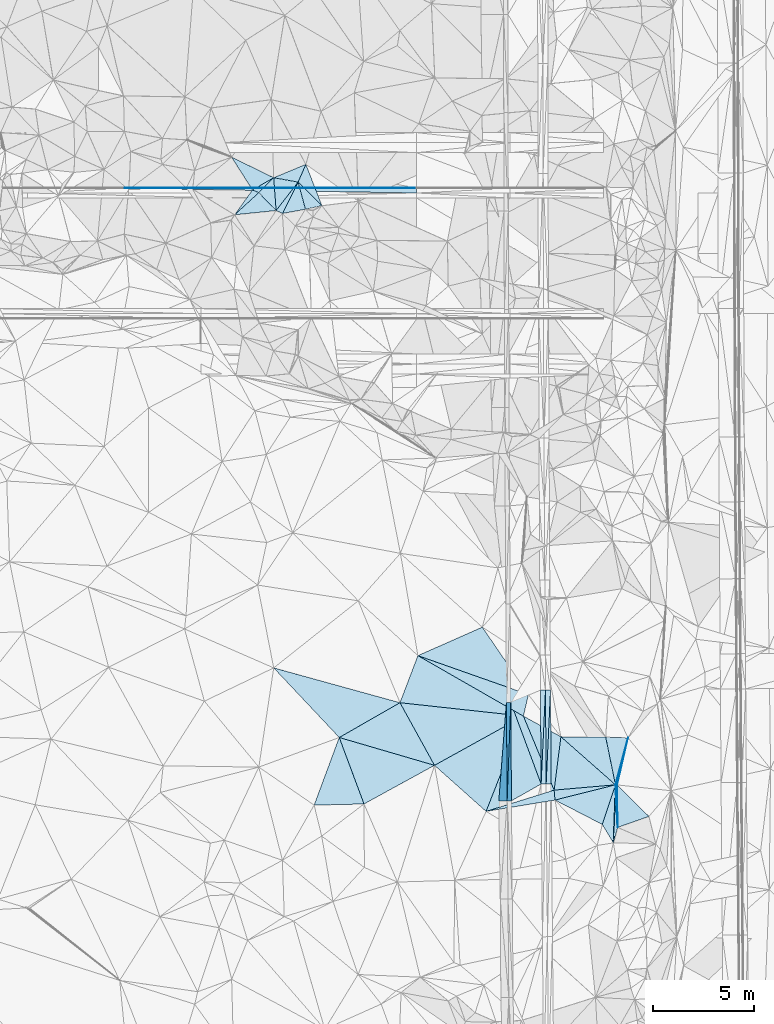
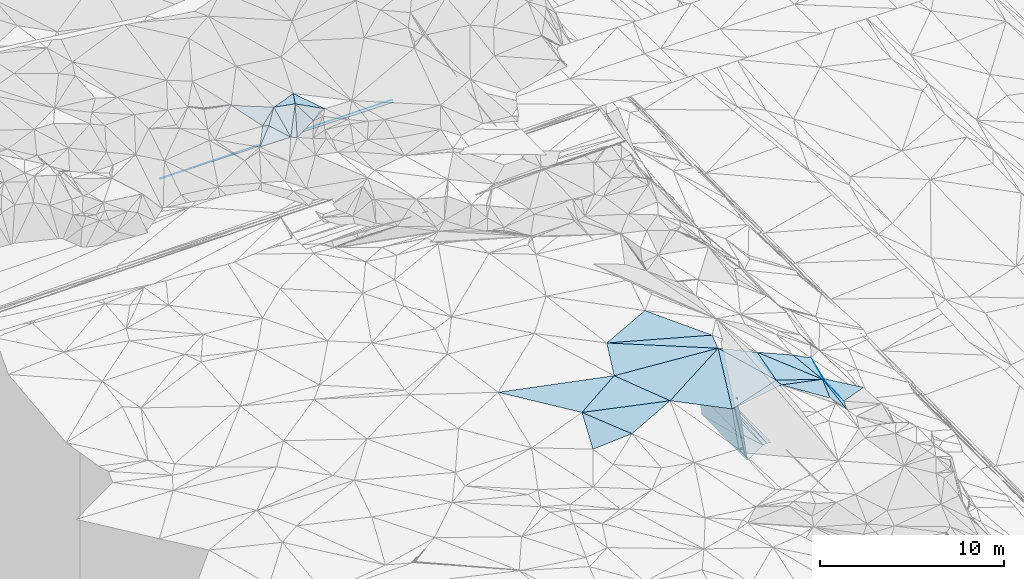
# One storey, part 51 of 275: 45 plates.
"""IFC2X3 building model written with IfcOpenShell, lengths in millimetres."""

from ifc_helpers import new_model, si_unit, frame, origin_with_axes, place, context, subcontext, project, spatial, polyline, outline, extrude, material, type_object, element, save


model = new_model("IFC2X3")

# Units and contexts
model_context = context("Model", 3, precision=1e-05, world=origin_with_axes())
body_context = subcontext(model_context, "Body", "Model", "MODEL_VIEW")
ifc_project = project(units=[si_unit("LENGTHUNIT", "METRE", prefix="MILLI"), si_unit("AREAUNIT", "SQUARE_METRE"), si_unit("VOLUMEUNIT", "CUBIC_METRE"), si_unit("MASSUNIT", "GRAM", prefix="KILO"), si_unit("TIMEUNIT", "SECOND"), si_unit("PLANEANGLEUNIT", "RADIAN"), si_unit("SOLIDANGLEUNIT", "STERADIAN"), si_unit("THERMODYNAMICTEMPERATUREUNIT", "DEGREE_CELSIUS"), si_unit("LUMINOUSINTENSITYUNIT", "LUMEN")], contexts=[model_context])

# Site, building, storey
site_placement = place(None, origin_with_axes())
site = spatial("IfcSite", under=ifc_project, at=site_placement, CompositionType="ELEMENT")
building_placement = place(site_placement, origin_with_axes())
building = spatial("IfcBuilding", under=site, at=building_placement, Name="Undefined", CompositionType="ELEMENT")
storey_placement = place(building_placement, origin_with_axes())
storey = spatial("IfcBuildingStorey", under=building, at=storey_placement, Name="Undefined", CompositionType="ELEMENT", Elevation=0.0)

# Plates
ifc_material = material()
plate_type_1 = type_object("IfcPlateType", PredefinedType="NOTDEFINED")
plate_1_placement = place(storey_placement, frame((-105610.177869525, 36086.7993758468, 43457.3042915249), z_axis=(-0.989939803691774, -0.00440192460709895, -0.141420677860221), x_axis=(0.0350655499224098, 0.960701127197232, -0.275361129084349)))
element("IfcPlate", 1, at=plate_1_placement, inside=storey, type_object=plate_type_1, material=ifc_material, Name="00_PR", context=body_context, shape_type="SweptSolid", body=[
    extrude(outline(polyline([(0.0, 0.0), (5086.42578125, 1.38097675517201e-08), (422.152801513672, 1455.23388671875), (0.0, 0.0)])), frame((-8.85201319254618e-08, 2.18876761149539e-07, -0.5000001331573), z_axis=(0.0, 0.0, 1.0), x_axis=(1.0, 0.0, 0.0)), (0.0, 0.0, 1.0), 1.0),
])
plate_2_placement = place(storey_placement, frame((-105431.819547639, 40973.3345378845, 42056.7002909568), z_axis=(-0.989939803691774, -0.00440192460709895, -0.141420677860221), x_axis=(-0.0350655498984951, -0.960701127203394, 0.275361129065896)))
element("IfcPlate", 2, at=plate_2_placement, inside=storey, type_object=plate_type_1, material=ifc_material, Name="00_PR", context=body_context, shape_type="SweptSolid", body=[
    extrude(outline(polyline([(0.0, 0.0), (5086.42578125, 1.38097675517201e-08), (421.985900878906, 1455.28210449219), (0.0, 0.0)])), frame((-8.85201319254618e-08, 2.18876761149539e-07, -0.5000001331573), z_axis=(0.0, 0.0, 1.0), x_axis=(1.0, 0.0, 0.0)), (0.0, 0.0, 1.0), 1.0),
])
plate_type_2 = type_object("IfcPlateType", PredefinedType="NOTDEFINED")
plate_3_placement = place(storey_placement, frame((-103955.471875888, 41583.2969759168, 42068.7577290089), z_axis=(0.04978637505369, 0.0207301321015201, -0.998544730336136), x_axis=(0.998728898729614, 0.00684263509305449, 0.0499376129517273)))
element("IfcPlate", 3, at=plate_3_placement, inside=storey, type_object=plate_type_2, material=ifc_material, Name="00_PR", context=body_context, shape_type="SweptSolid", body=[
    extrude(outline(polyline([(0.0, 0.0), (250.31233215332, -1.60071067512035e-10), (-2.96082162857056, 4664.6181640625), (0.0, 0.0)])), frame((-8.85201319254618e-08, 2.18876761149539e-07, -0.5000001331573), z_axis=(0.0, 0.0, 1.0), x_axis=(1.0, 0.0, 0.0)), (0.0, 0.0, 1.0), 1.0),
])
plate_4_placement = place(storey_placement, frame((-103705.477733984, 41585.0097738351, 42081.2577288666), z_axis=(0.0497706300846513, 0.0207308805935782, -0.998545499699834), x_axis=(0.00723401010920454, -0.999765815858548, -0.0203956499879605)))
element("IfcPlate", 4, at=plate_4_placement, inside=storey, type_object=plate_type_2, material=ifc_material, Name="00_PR", context=body_context, shape_type="SweptSolid", body=[
    extrude(outline(polyline([(0.0, 0.0), (4664.42626953125, -4.16184775531292e-09), (4664.77783203125, 250.31233215332), (0.0, 0.0)])), frame((-8.85201319254618e-08, 2.18876761149539e-07, -0.5000001331573), z_axis=(0.0, 0.0, 1.0), x_axis=(1.0, 0.0, 0.0)), (0.0, 0.0, 1.0), 1.0),
])
plate_5_placement = place(storey_placement, frame((-103671.770192985, 36921.6757792332, 41986.1232049827), z_axis=(-0.0201467526194381, 0.020247175914871, -0.999591996879909), x_axis=(0.0462974798819486, 0.998741295879206, 0.0192968199997953)))
element("IfcPlate", 5, at=plate_5_placement, inside=storey, type_object=plate_type_2, material=ifc_material, Name="00_PR", context=body_context, shape_type="SweptSolid", body=[
    extrude(outline(polyline([(0.0, 0.0), (4670.9248046875, 1.68511178344488e-08), (13.3809785842896, 249.691986083984), (0.0, 0.0)])), frame((-8.85201319254618e-08, 2.18876761149539e-07, -0.5000001331573), z_axis=(0.0, 0.0, 1.0), x_axis=(1.0, 0.0, 0.0)), (0.0, 0.0, 1.0), 1.0),
])
plate_6_placement = place(storey_placement, frame((-103455.518128, 41586.7214102786, 42076.2572045192), z_axis=(-0.0201309233659579, 0.020246448567796, -0.999592330525213), x_axis=(-0.0462974798643464, -0.998741295880311, -0.0192968199848568)))
element("IfcPlate", 6, at=plate_6_placement, inside=storey, type_object=plate_type_2, material=ifc_material, Name="00_PR", context=body_context, shape_type="SweptSolid", body=[
    extrude(outline(polyline([(0.0, 0.0), (4670.9248046875, 1.68511178344488e-08), (13.1873588562012, 249.702423095703), (0.0, 0.0)])), frame((-8.85201319254618e-08, 2.18876761149539e-07, -0.5000001331573), z_axis=(0.0, 0.0, 1.0), x_axis=(1.0, 0.0, 0.0)), (0.0, 0.0, 1.0), 1.0),
])
plate_type_3 = type_object("IfcPlateType", PredefinedType="NOTDEFINED")
plate_7_placement = place(storey_placement, frame((-110107.784869817, 66523.1757548993, 49043.1746354216), z_axis=(0.0083122519702356, -0.0499355339048205, -0.998717852509318), x_axis=(-0.999965344853481, 5.72919765649429e-05, -0.00832501109232228)))
element("IfcPlate", 7, at=plate_7_placement, inside=storey, type_object=plate_type_3, material=ifc_material, Name="00_PR", context=body_context, shape_type="SweptSolid", body=[
    extrude(outline(polyline([(0.0, 0.0), (14503.03515625, 1.02263584267348e-07), (14503.04296875, 20.0253067016602), (0.0, 0.0)])), frame((-8.85201319254618e-08, 2.18876761149539e-07, -0.5000001331573), z_axis=(0.0, 0.0, 1.0), x_axis=(1.0, 0.0, 0.0)), (0.0, 0.0, 1.0), 1.0),
])
plate_8_placement = place(storey_placement, frame((-110107.783378065, 66543.1751632151, 49042.1746356091), z_axis=(0.00831224750610881, -0.0499379782776763, -0.998717730325709), x_axis=(-7.46349832174646e-05, -0.998752262639263, 0.0499390859204745)))
element("IfcPlate", 8, at=plate_8_placement, inside=storey, type_object=plate_type_3, material=ifc_material, Name="00_PR", context=body_context, shape_type="SweptSolid", body=[
    extrude(outline(polyline([(0.0, 0.0), (20.0243949890137, 1.30967237055302e-10), (-5.77852153778076, 14503.0341796875), (0.0, 0.0)])), frame((-8.85201319254618e-08, 2.18876761149539e-07, -0.5000001331573), z_axis=(0.0, 0.0, 1.0), x_axis=(1.0, 0.0, 0.0)), (0.0, 0.0, 1.0), 1.0),
])
plate_type_4 = type_object("IfcPlateType", PredefinedType="NOTDEFINED")
plate_9_placement = place(storey_placement, frame((-110107.797697008, 66293.1751613901, 49054.6746353648), z_axis=(0.0083122519702356, -0.0499355339048205, -0.998717852509318), x_axis=(-0.999831796750404, 0.0159139679508105, -0.00911722715080215)))
element("IfcPlate", 9, at=plate_9_placement, inside=storey, type_object=plate_type_4, material=ifc_material, Name="00_PR", context=body_context, shape_type="SweptSolid", body=[
    extrude(outline(polyline([(0.0, 0.0), (14504.958984375, -2.8521753847599e-09), (3.75224280357361, 230.257339477539), (0.0, 0.0)])), frame((-8.85201319254618e-08, 2.18876761149539e-07, -0.5000001331573), z_axis=(0.0, 0.0, 1.0), x_axis=(1.0, 0.0, 0.0)), (0.0, 0.0, 1.0), 1.0),
])
plate_type_5 = type_object("IfcPlateType", PredefinedType="NOTDEFINED")
plate_10_placement = place(storey_placement, frame((-106025.594184139, 36083.5762148779, 46365.3042915135), z_axis=(-0.989939803691774, -0.00440192460709895, -0.141420677860221), x_axis=(0.0671619919290015, 0.865113351109741, -0.497059510090897)))
element("IfcPlate", 10, at=plate_10_placement, inside=storey, type_object=plate_type_5, material=ifc_material, Name="00_PR", context=body_context, shape_type="SweptSolid", body=[
    extrude(outline(polyline([(0.0, 0.0), (5650.43798828125, -3.55066731572151e-09), (1476.1376953125, 2539.697265625), (0.0, 0.0)])), frame((-8.85201319254618e-08, 2.18876761149539e-07, -0.5000001331573), z_axis=(0.0, 0.0, 1.0), x_axis=(1.0, 0.0, 0.0)), (0.0, 0.0, 1.0), 1.0),
])
plate_type_6 = type_object("IfcPlateType", PredefinedType="NOTDEFINED")
plate_11_placement = place(storey_placement, frame((-103921.753107992, 36919.770039862, 41973.6231055061), z_axis=(2.92306813592987e-05, 0.020395550804748, -0.999791988692117), x_axis=(-0.348926645087873, 0.936955309961213, 0.0191034940052851)))
element("IfcPlate", 11, at=plate_11_placement, inside=storey, type_object=plate_type_6, material=ifc_material, Name="00_PR", context=body_context, shape_type="SweptSolid", body=[
    extrude(outline(polyline([(0.0, 0.0), (4326.3291015625, 1.94413587450981e-08), (4383.107421875, 1595.94445800781), (0.0, 0.0)])), frame((-8.85201319254618e-08, 2.18876761149539e-07, -0.5000001331573), z_axis=(0.0, 0.0, 1.0), x_axis=(1.0, 0.0, 0.0)), (0.0, 0.0, 1.0), 1.0),
])
plate_12_placement = place(storey_placement, frame((-105395.403264539, 36088.4743412056, 41956.8751051901), z_axis=(-0.000112811193605053, 0.0203426754219247, -0.999793060003075), x_axis=(-0.00735187309506979, 0.999766029701192, 0.0203429549846987)))
element("IfcPlate", 12, at=plate_12_placement, inside=storey, type_object=plate_type_6, material=ifc_material, Name="00_PR", context=body_context, shape_type="SweptSolid", body=[
    extrude(outline(polyline([(0.0, 0.0), (4886.015625, 7.88713805377483e-09), (820.607788085938, 1479.72314453125), (0.0, 0.0)])), frame((-8.85201319254618e-08, 2.18876761149539e-07, -0.5000001331573), z_axis=(0.0, 0.0, 1.0), x_axis=(1.0, 0.0, 0.0)), (0.0, 0.0, 1.0), 1.0),
])
plate_type_7 = type_object("IfcPlateType", PredefinedType="NOTDEFINED")
plate_13_placement = place(storey_placement, frame((-103231.607892025, 36123.691654769, 46199.5009324228), z_axis=(0.00742708887413916, 0.0612008864523576, -0.998097835809848), x_axis=(-0.986614216456541, -0.16215312264328, -0.0172844642057567)))
element("IfcPlate", 13, at=plate_13_placement, inside=storey, type_object=plate_type_7, material=ifc_material, Name="00", context=body_context, shape_type="SweptSolid", body=[
    extrude(outline(polyline([(0.0, 0.0), (3471.32543945313, 1.13868736661971e-08), (-37.5937080383301, 495.970489501953), (0.0, 0.0)])), frame((-8.85201319254618e-08, 2.18876761149539e-07, -0.5000001331573), z_axis=(0.0, 0.0, 1.0), x_axis=(1.0, 0.0, 0.0)), (0.0, 0.0, 1.0), 1.0),
])
plate_type_8 = type_object("IfcPlateType", PredefinedType="NOTDEFINED")
plate_14_placement = place(storey_placement, frame((-104802.275117274, 40294.815248189, 46649.5046051497), z_axis=(0.0273700535457187, 0.132862698192638, -0.990756470379011), x_axis=(-0.871485887713949, -0.482322276628338, -0.0887556701483729)))
element("IfcPlate", 14, at=plate_14_placement, inside=storey, type_object=plate_type_8, material=ifc_material, Name="00", context=body_context, shape_type="SweptSolid", body=[
    extrude(outline(polyline([(0.0, 0.0), (5070.0986328125, 9.32777766138315e-09), (5030.6123046875, 3572.53979492188), (0.0, 0.0)])), frame((-8.85201319254618e-08, 2.18876761149539e-07, -0.5000001331573), z_axis=(0.0, 0.0, 1.0), x_axis=(1.0, 0.0, 0.0)), (0.0, 0.0, 1.0), 1.0),
])
plate_type_9 = type_object("IfcPlateType", PredefinedType="NOTDEFINED")
plate_15_placement = place(storey_placement, frame((-117211.148070215, 67052.2340394093, 50749.5010894158), z_axis=(-0.0496229456251874, 0.0443945159407764, -0.997780882870515), x_axis=(0.923323926198926, 0.38293440668302, -0.0288819578097515)))
element("IfcPlate", 15, at=plate_15_placement, inside=storey, type_object=plate_type_9, material=ifc_material, Name="00", context=body_context, shape_type="SweptSolid", body=[
    extrude(outline(polyline([(0.0, 0.0), (1731.1845703125, -4.51109372079372e-09), (1037.2666015625, 667.441345214844), (0.0, 0.0)])), frame((-8.85201319254618e-08, 2.18876761149539e-07, -0.5000001331573), z_axis=(0.0, 0.0, 1.0), x_axis=(1.0, 0.0, 0.0)), (0.0, 0.0, 1.0), 1.0),
])
plate_type_10 = type_object("IfcPlateType", PredefinedType="NOTDEFINED")
plate_16_placement = place(storey_placement, frame((-119151.980647659, 65210.2189330706, 49909.5118916253), z_axis=(0.0866031978329641, 0.198832517231406, -0.976199526847113), x_axis=(0.570298220554886, 0.793549529744989, 0.212224134992788)))
element("IfcPlate", 16, at=plate_16_placement, inside=storey, type_object=plate_type_10, material=ifc_material, Name="00", context=body_context, shape_type="SweptSolid", body=[
    extrude(outline(polyline([(0.0, 0.0), (1554.95983886719, 1.07684172689915e-08), (1624.92944335938, 332.421783447266), (0.0, 0.0)])), frame((-8.85201319254618e-08, 2.18876761149539e-07, -0.5000001331573), z_axis=(0.0, 0.0, 1.0), x_axis=(1.0, 0.0, 0.0)), (0.0, 0.0, 1.0), 1.0),
])
plate_type_11 = type_object("IfcPlateType", PredefinedType="NOTDEFINED")
plate_17_placement = place(storey_placement, frame((-115999.227777042, 66833.5751395037, 50679.5001216073), z_axis=(-0.00202183068912543, 0.0235667452234005, -0.999720221222038), x_axis=(0.401479410767836, 0.915632449879914, 0.0207725649937047)))
element("IfcPlate", 17, at=plate_17_placement, inside=storey, type_object=plate_type_11, material=ifc_material, Name="00", context=body_context, shape_type="SweptSolid", body=[
    extrude(outline(polyline([(0.0, 0.0), (962.808410644531, 3.69618646800518e-09), (-597.211242675781, 1555.26159667969), (0.0, 0.0)])), frame((-8.85201319254618e-08, 2.18876761149539e-07, -0.5000001331573), z_axis=(0.0, 0.0, 1.0), x_axis=(1.0, 0.0, 0.0)), (0.0, 0.0, 1.0), 1.0),
])
plate_type_12 = type_object("IfcPlateType", PredefinedType="NOTDEFINED")
plate_18_placement = place(storey_placement, frame((-109220.792669373, 37849.3947307043, 46199.5047921093), z_axis=(0.0310585921688343, 0.134850213391363, -0.990379111149258), x_axis=(-0.959785112272291, 0.280618544369442, 0.00810992086524173)))
element("IfcPlate", 18, at=plate_18_placement, inside=storey, type_object=plate_type_12, material=ifc_material, Name="00", context=body_context, shape_type="SweptSolid", body=[
    extrude(outline(polyline([(0.0, 0.0), (4932.23095703125, -1.04992068372667e-08), (2522.3271484375, 2530.30932617188), (0.0, 0.0)])), frame((-8.85201319254618e-08, 2.18876761149539e-07, -0.5000001331573), z_axis=(0.0, 0.0, 1.0), x_axis=(1.0, 0.0, 0.0)), (0.0, 0.0, 1.0), 1.0),
])
plate_type_13 = type_object("IfcPlateType", PredefinedType="NOTDEFINED")
plate_19_placement = place(storey_placement, frame((-100227.004003901, 36882.4327597286, 45057.5337865957), z_axis=(-0.360600804456206, 0.0246925953112589, -0.932393337364833), x_axis=(-0.909763929634358, -0.229730656567818, 0.345764974757668)))
element("IfcPlate", 19, at=plate_19_placement, inside=storey, type_object=plate_type_13, material=ifc_material, Name="00", context=body_context, shape_type="SweptSolid", body=[
    extrude(outline(polyline([(0.0, 0.0), (3302.82153320313, 1.7571437638253e-08), (3239.33935546875, 493.325469970703), (0.0, 0.0)])), frame((-8.85201319254618e-08, 2.18876761149539e-07, -0.5000001331573), z_axis=(0.0, 0.0, 1.0), x_axis=(1.0, 0.0, 0.0)), (0.0, 0.0, 1.0), 1.0),
])
plate_type_14 = type_object("IfcPlateType", PredefinedType="NOTDEFINED")
plate_20_placement = place(storey_placement, frame((-115999.044269854, 66833.7491732781, 50679.5731714106), z_axis=(0.364993116120657, 0.371634365480564, -0.853620479826012), x_axis=(0.250528942199184, -0.92226139595634, -0.294396274856225)))
element("IfcPlate", 20, at=plate_20_placement, inside=storey, type_object=plate_type_14, material=ifc_material, Name="00", context=body_context, shape_type="SweptSolid", body=[
    extrude(outline(polyline([(0.0, 0.0), (1460.61633300781, -5.355104804039e-09), (1538.73400878906, 1296.18579101563), (0.0, 0.0)])), frame((-8.85201319254618e-08, 2.18876761149539e-07, -0.5000001331573), z_axis=(0.0, 0.0, 1.0), x_axis=(1.0, 0.0, 0.0)), (0.0, 0.0, 1.0), 1.0),
])
plate_type_15 = type_object("IfcPlateType", PredefinedType="NOTDEFINED")
plate_21_placement = place(storey_placement, frame((-115999.167016444, 66833.8121878348, 50679.5704317872), z_axis=(0.11948776150954, 0.497663490181441, -0.859100532760786), x_axis=(-0.386076146737204, -0.773906822068669, -0.50200940197981)))
element("IfcPlate", 21, at=plate_21_placement, inside=storey, type_object=plate_type_15, material=ifc_material, Name="00", context=body_context, shape_type="SweptSolid", body=[
    extrude(outline(polyline([(0.0, 0.0), (2011.91455078125, -1.08266249299049e-08), (2001.57604980469, 349.275115966797), (0.0, 0.0)])), frame((-8.85201319254618e-08, 2.18876761149539e-07, -0.5000001331573), z_axis=(0.0, 0.0, 1.0), x_axis=(1.0, 0.0, 0.0)), (0.0, 0.0, 1.0), 1.0),
])
plate_type_16 = type_object("IfcPlateType", PredefinedType="NOTDEFINED")
plate_22_placement = place(storey_placement, frame((-117953.852493185, 66308.6106415906, 50239.5491667078), z_axis=(-0.129799685007448, 0.412529551852355, -0.90164927251147), x_axis=(0.640709407361097, -0.659103961057011, -0.39379363102766)))
element("IfcPlate", 22, at=plate_22_placement, inside=storey, type_object=plate_type_16, material=ifc_material, Name="00", context=body_context, shape_type="SweptSolid", body=[
    extrude(outline(polyline([(0.0, 0.0), (1345.88256835938, -8.53469828143716e-09), (86.1144943237305, 1656.3466796875), (0.0, 0.0)])), frame((-8.85201319254618e-08, 2.18876761149539e-07, -0.5000001331573), z_axis=(0.0, 0.0, 1.0), x_axis=(1.0, 0.0, 0.0)), (0.0, 0.0, 1.0), 1.0),
])
plate_type_17 = type_object("IfcPlateType", PredefinedType="NOTDEFINED")
plate_23_placement = place(storey_placement, frame((-117211.104316151, 67052.4814477353, 50749.5793406755), z_axis=(0.0376528748299306, 0.539252993773244, -0.84130165203905), x_axis=(0.0617427732365714, -0.841545545998717, -0.536645995012335)))
element("IfcPlate", 23, at=plate_23_placement, inside=storey, type_object=plate_type_17, material=ifc_material, Name="00", context=body_context, shape_type="SweptSolid", body=[
    extrude(outline(polyline([(0.0, 0.0), (1937.962890625, -1.16415321826935e-08), (853.783142089844, 797.467468261719), (0.0, 0.0)])), frame((-8.85201319254618e-08, 2.18876761149539e-07, -0.5000001331573), z_axis=(0.0, 0.0, 1.0), x_axis=(1.0, 0.0, 0.0)), (0.0, 0.0, 1.0), 1.0),
])
plate_type_18 = type_object("IfcPlateType", PredefinedType="NOTDEFINED")
plate_24_placement = place(storey_placement, frame((-118265.140855826, 66444.2690135255, 50239.5566026821), z_axis=(0.18456632635573, 0.423746326943744, -0.886777492710114), x_axis=(0.798866249879136, 0.460895212161646, 0.386507850127934)))
element("IfcPlate", 24, at=plate_24_placement, inside=storey, type_object=plate_type_18, material=ifc_material, Name="00", context=body_context, shape_type="SweptSolid", body=[
    extrude(outline(polyline([(0.0, 0.0), (1319.50744628906, 6.51925802230835e-09), (186.281631469727, 284.075958251953), (0.0, 0.0)])), frame((-8.85201319254618e-08, 2.18876761149539e-07, -0.5000001331573), z_axis=(0.0, 0.0, 1.0), x_axis=(1.0, 0.0, 0.0)), (0.0, 0.0, 1.0), 1.0),
])
plate_type_19 = type_object("IfcPlateType", PredefinedType="NOTDEFINED")
plate_25_placement = place(storey_placement, frame((-117091.443544303, 65421.5976049566, 49709.5797303225), z_axis=(0.0487999333596636, 0.539574088715331, -0.840522676250387), x_axis=(-0.0617427722412453, 0.841545546052108, 0.536645995043124)))
element("IfcPlate", 25, at=plate_25_placement, inside=storey, type_object=plate_type_19, material=ifc_material, Name="00", context=body_context, shape_type="SweptSolid", body=[
    extrude(outline(polyline([(0.0, 0.0), (1937.962890625, -1.16415321826935e-08), (1641.56909179688, 1197.30981445313), (0.0, 0.0)])), frame((-8.85201319254618e-08, 2.18876761149539e-07, -0.5000001331573), z_axis=(0.0, 0.0, 1.0), x_axis=(1.0, 0.0, 0.0)), (0.0, 0.0, 1.0), 1.0),
])
plate_type_20 = type_object("IfcPlateType", PredefinedType="NOTDEFINED")
plate_26_placement = place(storey_placement, frame((-100227.005533462, 36882.440093995, 45057.5346345615), z_axis=(-0.363661024189093, 0.0393609994788594, -0.930699398949932), x_axis=(-0.313585122373435, -0.945967368253664, 0.0825233859295387)))
element("IfcPlate", 26, at=plate_26_placement, inside=storey, type_object=plate_type_20, material=ifc_material, Name="00", context=body_context, shape_type="SweptSolid", body=[
    extrude(outline(polyline([(0.0, 0.0), (2084.25756835938, -5.20958565175533e-09), (1754.26013183594, 2798.42846679688), (0.0, 0.0)])), frame((-8.85201319254618e-08, 2.18876761149539e-07, -0.5000001331573), z_axis=(0.0, 0.0, 1.0), x_axis=(1.0, 0.0, 0.0)), (0.0, 0.0, 1.0), 1.0),
])
plate_type_21 = type_object("IfcPlateType", PredefinedType="NOTDEFINED")
plate_27_placement = place(storey_placement, frame((-99601.6981871568, 39215.3134219974, 44839.5084482782), z_axis=(0.131778338928425, -0.12717018126884, -0.98308810102926), x_axis=(-0.224261958865943, -0.969848506058675, 0.0953962740434138)))
element("IfcPlate", 27, at=plate_27_placement, inside=storey, type_object=plate_type_21, material=ifc_material, Name="00", context=body_context, shape_type="SweptSolid", body=[
    extrude(outline(polyline([(0.0, 0.0), (2410.99560546875, -4.19095158576965e-09), (2423.587890625, 84.4478149414063), (0.0, 0.0)])), frame((-8.85201319254618e-08, 2.18876761149539e-07, -0.5000001331573), z_axis=(0.0, 0.0, 1.0), x_axis=(1.0, 0.0, 0.0)), (0.0, 0.0, 1.0), 1.0),
])
plate_type_22 = type_object("IfcPlateType", PredefinedType="NOTDEFINED")
plate_28_placement = place(storey_placement, frame((-100227.048059431, 36882.438810667, 45057.5535759862), z_axis=(-0.448878704291487, 0.0368366469394615, -0.892833114459725), x_axis=(-0.198814135146236, 0.969989613807595, 0.13997531486461)))
element("IfcPlate", 28, at=plate_28_placement, inside=storey, type_object=plate_type_22, material=ifc_material, Name="00", context=body_context, shape_type="SweptSolid", body=[
    extrude(outline(polyline([(0.0, 0.0), (2443.28784179688, 2.91038304567337e-11), (2108.15844726563, 1198.57336425781), (0.0, 0.0)])), frame((-8.85201319254618e-08, 2.18876761149539e-07, -0.5000001331573), z_axis=(0.0, 0.0, 1.0), x_axis=(1.0, 0.0, 0.0)), (0.0, 0.0, 1.0), 1.0),
])
plate_type_23 = type_object("IfcPlateType", PredefinedType="NOTDEFINED")
plate_29_placement = place(storey_placement, frame((-100117.082785901, 34767.1855707074, 44849.5081476814), z_axis=(0.146527488028692, 0.10432477402276, -0.983690010509968), x_axis=(-0.0515278551751076, 0.993878140882975, 0.0977298379004816)))
element("IfcPlate", 29, at=plate_29_placement, inside=storey, type_object=plate_type_23, material=ifc_material, Name="00", context=body_context, shape_type="SweptSolid", body=[
    extrude(outline(polyline([(0.0, 0.0), (2128.31616210938, -5.66069502383471e-09), (2119.83056640625, 84.9587860107422), (0.0, 0.0)])), frame((-8.85201319254618e-08, 2.18876761149539e-07, -0.5000001331573), z_axis=(0.0, 0.0, 1.0), x_axis=(1.0, 0.0, 0.0)), (0.0, 0.0, 1.0), 1.0),
])
plate_type_24 = type_object("IfcPlateType", PredefinedType="NOTDEFINED")
plate_30_placement = place(storey_placement, frame((-100142.46402371, 36877.1282694993, 45069.5027100763), z_axis=(-0.0106823633652873, 0.103573356434371, -0.994564450877795), x_axis=(0.707508397847598, -0.702080628605874, -0.0807134307999987)))
element("IfcPlate", 30, at=plate_30_placement, inside=storey, type_object=plate_type_24, material=ifc_material, Name="00", context=body_context, shape_type="SweptSolid", body=[
    extrude(outline(polyline([(0.0, 0.0), (2230.11206054688, 1.03027559816837e-08), (1517.00891113281, 1483.09936523438), (0.0, 0.0)])), frame((-8.85201319254618e-08, 2.18876761149539e-07, -0.5000001331573), z_axis=(0.0, 0.0, 1.0), x_axis=(1.0, 0.0, 0.0)), (0.0, 0.0, 1.0), 1.0),
])
plate_type_25 = type_object("IfcPlateType", PredefinedType="NOTDEFINED")
plate_31_placement = place(storey_placement, frame((-100330.128720965, 33997.3534493102, 44807.5063983683), z_axis=(-0.131582718089797, 0.0902500834411527, -0.987188386651183), x_axis=(0.0356272448194127, 0.995634265987863, 0.0862734479280095)))
element("IfcPlate", 31, at=plate_31_placement, inside=storey, type_object=plate_type_25, material=ifc_material, Name="00", context=body_context, shape_type="SweptSolid", body=[
    extrude(outline(polyline([(0.0, 0.0), (2897.76293945313, -5.77711034566164e-09), (777.672973632813, 186.945709228516), (0.0, 0.0)])), frame((-8.85201319254618e-08, 2.18876761149539e-07, -0.5000001331573), z_axis=(0.0, 0.0, 1.0), x_axis=(1.0, 0.0, 0.0)), (0.0, 0.0, 1.0), 1.0),
])
plate_type_26 = type_object("IfcPlateType", PredefinedType="NOTDEFINED")
plate_32_placement = place(storey_placement, frame((-115633.128832959, 65486.6777840225, 50249.5680002098), z_axis=(0.342766977235124, 0.36889700776119, -0.863959372298221), x_axis=(-0.250528942564715, 0.922261395817771, 0.294396274979259)))
element("IfcPlate", 32, at=plate_32_placement, inside=storey, type_object=plate_type_26, material=ifc_material, Name="00", context=body_context, shape_type="SweptSolid", body=[
    extrude(outline(polyline([(0.0, 0.0), (1460.61633300781, -5.355104804039e-09), (75.0368194580078, 925.024047851563), (0.0, 0.0)])), frame((-8.85201319254618e-08, 2.18876761149539e-07, -0.5000001331573), z_axis=(0.0, 0.0, 1.0), x_axis=(1.0, 0.0, 0.0)), (0.0, 0.0, 1.0), 1.0),
])
plate_type_27 = type_object("IfcPlateType", PredefinedType="NOTDEFINED")
plate_33_placement = place(storey_placement, frame((-104802.288401622, 40294.8089357296, 46649.5036107707), z_axis=(0.000785619587101313, 0.12023848917594, -0.992744724751812), x_axis=(-0.865971244186031, 0.496546972298119, 0.0594550968754534)))
element("IfcPlate", 33, at=plate_33_placement, inside=storey, type_object=plate_type_27, material=ifc_material, Name="00", context=body_context, shape_type="SweptSolid", body=[
    extrude(outline(polyline([(0.0, 0.0), (6054.98974609375, 1.04555510915816e-08), (325.285430908203, 1058.81506347656), (0.0, 0.0)])), frame((-8.85201319254618e-08, 2.18876761149539e-07, -0.5000001331573), z_axis=(0.0, 0.0, 1.0), x_axis=(1.0, 0.0, 0.0)), (0.0, 0.0, 1.0), 1.0),
])
plate_type_28 = type_object("IfcPlateType", PredefinedType="NOTDEFINED")
plate_34_placement = place(storey_placement, frame((-119302.696561664, 68073.9397644908, 50989.5682385081), z_axis=(0.13786073268893, 0.48516778618547, -0.863485169316973), x_axis=(0.893831600529017, -0.436516257576595, -0.102560356703063)))
element("IfcPlate", 34, at=plate_34_placement, inside=storey, type_object=plate_type_28, material=ifc_material, Name="00", context=body_context, shape_type="SweptSolid", body=[
    extrude(outline(polyline([(0.0, 0.0), (2340.08544921875, 1.38534232974052e-08), (1715.66381835938, 1162.41027832031), (0.0, 0.0)])), frame((-8.85201319254618e-08, 2.18876761149539e-07, -0.5000001331573), z_axis=(0.0, 0.0, 1.0), x_axis=(1.0, 0.0, 0.0)), (0.0, 0.0, 1.0), 1.0),
])
plate_type_29 = type_object("IfcPlateType", PredefinedType="NOTDEFINED")
plate_35_placement = place(storey_placement, frame((-104554.470315039, 41366.5292518397, 46779.5035194945), z_axis=(0.000243918239129788, 0.118722823325738, -0.992927405063159), x_axis=(-0.942429126439991, 0.332068058414454, 0.0394733608704668)))
element("IfcPlate", 35, at=plate_35_placement, inside=storey, type_object=plate_type_29, material=ifc_material, Name="00", context=body_context, shape_type="SweptSolid", body=[
    extrude(outline(polyline([(0.0, 0.0), (5826.71435546875, 3.47627064911649e-08), (3286.53491210938, 2413.79125976563), (0.0, 0.0)])), frame((-8.85201319254618e-08, 2.18876761149539e-07, -0.5000001331573), z_axis=(0.0, 0.0, 1.0), x_axis=(1.0, 0.0, 0.0)), (0.0, 0.0, 1.0), 1.0),
])
plate_type_30 = type_object("IfcPlateType", PredefinedType="NOTDEFINED")
plate_36_placement = place(storey_placement, frame((-100227.005748077, 36882.4644627685, 45057.5363906759), z_axis=(-0.364093976212189, 0.0880978891714424, -0.927186247961829), x_axis=(-0.930357548339469, -0.0806298756686313, 0.357678144981538)))
element("IfcPlate", 36, at=plate_36_placement, inside=storey, type_object=plate_type_30, material=ifc_material, Name="00", context=body_context, shape_type="SweptSolid", body=[
    extrude(outline(polyline([(0.0, 0.0), (3276.68896484375, -2.30647856369615e-08), (2792.94750976563, 2632.279296875), (0.0, 0.0)])), frame((-8.85201319254618e-08, 2.18876761149539e-07, -0.5000001331573), z_axis=(0.0, 0.0, 1.0), x_axis=(1.0, 0.0, 0.0)), (0.0, 0.0, 1.0), 1.0),
])
plate_type_31 = type_object("IfcPlateType", PredefinedType="NOTDEFINED")
plate_37_placement = place(storey_placement, frame((-100880.668256779, 34910.8268963678, 45229.5708239183), z_axis=(-0.504719541366225, 0.0924355737131596, -0.858320365175723), x_axis=(0.313585122376846, 0.945967368252494, -0.0825233859299899)))
element("IfcPlate", 37, at=plate_37_placement, inside=storey, type_object=plate_type_31, material=ifc_material, Name="00", context=body_context, shape_type="SweptSolid", body=[
    extrude(outline(polyline([(0.0, 0.0), (2084.25756835938, -5.20958565175533e-09), (-656.707702636719, 940.286682128906), (0.0, 0.0)])), frame((-8.85201319254618e-08, 2.18876761149539e-07, -0.5000001331573), z_axis=(0.0, 0.0, 1.0), x_axis=(1.0, 0.0, 0.0)), (0.0, 0.0, 1.0), 1.0),
])
plate_type_32 = type_object("IfcPlateType", PredefinedType="NOTDEFINED")
plate_38_placement = place(storey_placement, frame((-113954.665309505, 39233.3876795989, 46239.5008094443), z_axis=(0.0490271798672995, -0.0300732114560834, -0.998344598616619), x_axis=(0.348799285754676, -0.936100689087504, 0.0453272340533507)))
element("IfcPlate", 38, at=plate_38_placement, inside=storey, type_object=plate_type_32, material=ifc_material, Name="00", context=body_context, shape_type="SweptSolid", body=[
    extrude(outline(polyline([(0.0, 0.0), (3529.88671875, -7.04312697052956e-09), (2713.34497070313, 2343.98364257813), (0.0, 0.0)])), frame((-8.85201319254618e-08, 2.18876761149539e-07, -0.5000001331573), z_axis=(0.0, 0.0, 1.0), x_axis=(1.0, 0.0, 0.0)), (0.0, 0.0, 1.0), 1.0),
])
plate_type_33 = type_object("IfcPlateType", PredefinedType="NOTDEFINED")
plate_39_placement = place(storey_placement, frame((-106656.443755236, 35560.8178891714, 46139.50256489), z_axis=(0.0536268238547193, 0.0861712555500485, -0.994836005822157), x_axis=(-0.74597354122029, 0.665746819270496, 0.0174541808881737)))
element("IfcPlate", 39, at=plate_39_placement, inside=storey, type_object=plate_type_33, material=ifc_material, Name="00", context=body_context, shape_type="SweptSolid", body=[
    extrude(outline(polyline([(0.0, 0.0), (3437.57177734375, -1.9237631931901e-08), (1777.35925292969, 4790.5732421875), (0.0, 0.0)])), frame((-8.85201319254618e-08, 2.18876761149539e-07, -0.5000001331573), z_axis=(0.0, 0.0, 1.0), x_axis=(1.0, 0.0, 0.0)), (0.0, 0.0, 1.0), 1.0),
])
plate_type_34 = type_object("IfcPlateType", PredefinedType="NOTDEFINED")
plate_40_placement = place(storey_placement, frame((-102939.300658954, 39270.6921144949, 46349.5406476698), z_axis=(-0.391543996222348, 0.0523168170272843, -0.918670914788516), x_axis=(0.919749299947921, -0.00755191433571257, -0.392433680811389)))
element("IfcPlate", 40, at=plate_40_placement, inside=storey, type_object=plate_type_34, material=ifc_material, Name="00", context=body_context, shape_type="SweptSolid", body=[
    extrude(outline(polyline([(0.0, 0.0), (2420.79125976563, 1.27038219943643e-08), (3019.67895507813, 2368.75268554688), (0.0, 0.0)])), frame((-8.85201319254618e-08, 2.18876761149539e-07, -0.5000001331573), z_axis=(0.0, 0.0, 1.0), x_axis=(1.0, 0.0, 0.0)), (0.0, 0.0, 1.0), 1.0),
])
plate_type_35 = type_object("IfcPlateType", PredefinedType="NOTDEFINED")
plate_41_placement = place(storey_placement, frame((-110935.697811979, 40961.7585866676, 46569.5049149284), z_axis=(0.0298576608992257, 0.136901318673573, -0.990134611571105), x_axis=(-0.863973068586068, -0.494602558565703, -0.0944396411377839)))
element("IfcPlate", 41, at=plate_41_placement, inside=storey, type_object=plate_type_35, material=ifc_material, Name="00", context=body_context, shape_type="SweptSolid", body=[
    extrude(outline(polyline([(0.0, 0.0), (3494.29541015625, 2.13040038943291e-08), (4561.3486328125, 4644.630859375), (0.0, 0.0)])), frame((-8.85201319254618e-08, 2.18876761149539e-07, -0.5000001331573), z_axis=(0.0, 0.0, 1.0), x_axis=(1.0, 0.0, 0.0)), (0.0, 0.0, 1.0), 1.0),
])
plate_type_36 = type_object("IfcPlateType", PredefinedType="NOTDEFINED")
plate_42_placement = place(storey_placement, frame((-104802.351813755, 40294.7792021992, 46649.504901128), z_axis=(-0.126028596760024, 0.0607710422996704, -0.990163457827298), x_axis=(0.867752438272556, -0.476952593337298, -0.139720898869354)))
element("IfcPlate", 42, at=plate_42_placement, inside=storey, type_object=plate_type_36, material=ifc_material, Name="00", context=body_context, shape_type="SweptSolid", body=[
    extrude(outline(polyline([(0.0, 0.0), (2147.1376953125, -1.00590114016086e-09), (3137.24658203125, 2486.48022460938), (0.0, 0.0)])), frame((-8.85201319254618e-08, 2.18876761149539e-07, -0.5000001331573), z_axis=(0.0, 0.0, 1.0), x_axis=(1.0, 0.0, 0.0)), (0.0, 0.0, 1.0), 1.0),
])
plate_type_37 = type_object("IfcPlateType", PredefinedType="NOTDEFINED")
plate_43_placement = place(storey_placement, frame((-103275.319935408, 36618.2765033459, 46229.5030454496), z_axis=(-0.00801294409382876, 0.110210616116971, -0.993875954444048), x_axis=(-0.954104950208748, -0.298393636791142, -0.0253964861687259)))
element("IfcPlate", 43, at=plate_43_placement, inside=storey, type_object=plate_type_37, material=ifc_material, Name="00", context=body_context, shape_type="SweptSolid", body=[
    extrude(outline(polyline([(0.0, 0.0), (3543.79736328125, 2.5189365260303e-08), (349.173461914063, 3987.85375976563), (0.0, 0.0)])), frame((-8.85201319254618e-08, 2.18876761149539e-07, -0.5000001331573), z_axis=(0.0, 0.0, 1.0), x_axis=(1.0, 0.0, 0.0)), (0.0, 0.0, 1.0), 1.0),
])
plate_type_38 = type_object("IfcPlateType", PredefinedType="NOTDEFINED")
plate_44_placement = place(storey_placement, frame((-104802.272970419, 40294.8353592139, 46649.5077841726), z_axis=(0.031660846950647, 0.173085042612033, -0.984397866106159), x_axis=(-0.994056284940876, 0.108092513307953, -0.0129657601518171)))
element("IfcPlate", 44, at=plate_44_placement, inside=storey, type_object=plate_type_38, material=ifc_material, Name="00", context=body_context, shape_type="SweptSolid", body=[
    extrude(outline(polyline([(0.0, 0.0), (6170.09716796875, -1.07611413113773e-08), (5532.60302734375, 2460.32543945313), (0.0, 0.0)])), frame((-8.85201319254618e-08, 2.18876761149539e-07, -0.5000001331573), z_axis=(0.0, 0.0, 1.0), x_axis=(1.0, 0.0, 0.0)), (0.0, 0.0, 1.0), 1.0),
])
plate_type_39 = type_object("IfcPlateType", PredefinedType="NOTDEFINED")
plate_45_placement = place(storey_placement, frame((-112723.480528305, 35929.0444796828, 46399.5009772954), z_axis=(-0.0253204364700304, -0.0577595500729517, -0.998009373639515), x_axis=(-0.348799285746424, 0.936100689090438, -0.0453272340562697)))
element("IfcPlate", 45, at=plate_45_placement, inside=storey, type_object=plate_type_39, material=ifc_material, Name="00", context=body_context, shape_type="SweptSolid", body=[
    extrude(outline(polyline([(0.0, 0.0), (3529.88671875, -7.04312697052956e-09), (584.891296386719, 3956.50122070313), (0.0, 0.0)])), frame((-8.85201319254618e-08, 2.18876761149539e-07, -0.5000001331573), z_axis=(0.0, 0.0, 1.0), x_axis=(1.0, 0.0, 0.0)), (0.0, 0.0, 1.0), 1.0),
])

save(model, "model.ifc")
